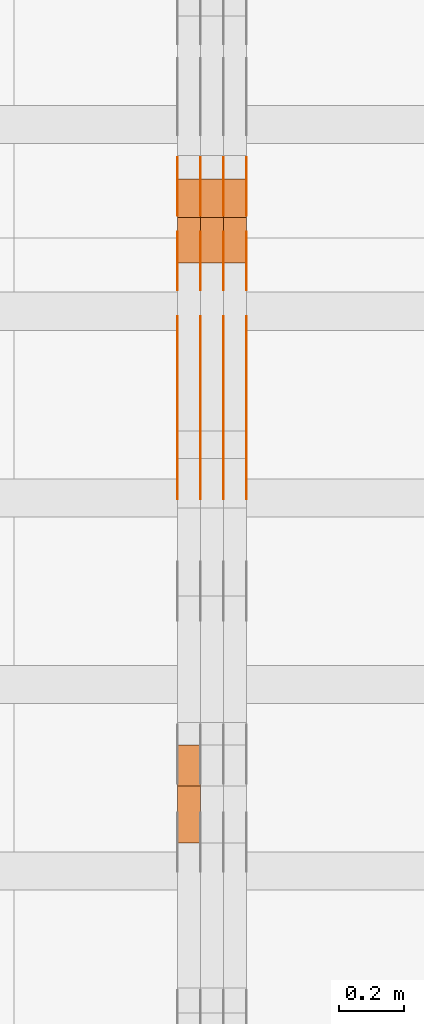
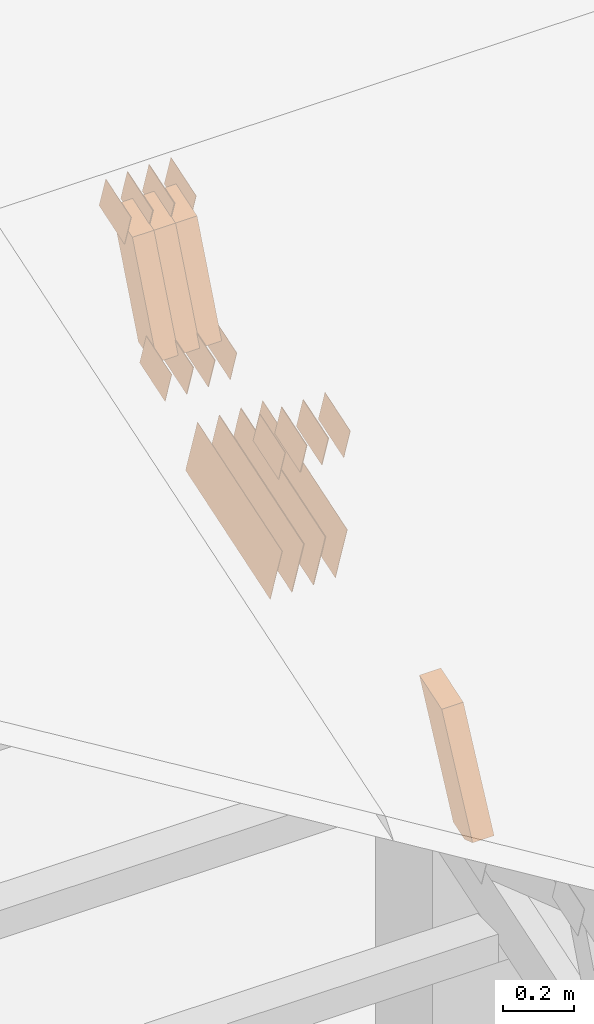
# One storey, part 139 of 385: 28 proxies.
"""IFC2X3 building model written with IfcOpenShell, lengths in millimetres."""

from ifc_helpers import new_model, entity, si_unit, converted_unit, derived_unit, direction, frame, origin, place, context, subcontext, project, spatial, polyline, outline, extrude, source, transform, mapped, material, type_object, type_shapes, element, save


model = new_model("IFC2X3")

# Units and contexts
model_context = context("Model", 3, precision=0.01, world=origin(), true_north=direction((6.12303176911189e-17, 1.0)))
body_context = subcontext(model_context, "Body", "Model", "MODEL_VIEW")
ifc_project = project(units=[si_unit("LENGTHUNIT", "METRE", prefix="MILLI"), si_unit("AREAUNIT", "SQUARE_METRE"), si_unit("VOLUMEUNIT", "CUBIC_METRE"), converted_unit("PLANEANGLEUNIT", "DEGREE", entity("IfcRatioMeasure", 0.0174532925199433), si_unit("PLANEANGLEUNIT", "RADIAN"), dimensions=[0, 0, 0, 0, 0, 0, 0]), si_unit("MASSUNIT", "GRAM", prefix="KILO"), derived_unit("MASSDENSITYUNIT", [(si_unit("MASSUNIT", "GRAM", prefix="KILO"), 1), (si_unit("LENGTHUNIT", "METRE"), -3)]), si_unit("TIMEUNIT", "SECOND"), si_unit("FREQUENCYUNIT", "HERTZ"), si_unit("THERMODYNAMICTEMPERATUREUNIT", "DEGREE_CELSIUS"), derived_unit("THERMALTRANSMITTANCEUNIT", [(si_unit("MASSUNIT", "GRAM", prefix="KILO"), 1), (si_unit("THERMODYNAMICTEMPERATUREUNIT", "KELVIN"), -1), (si_unit("TIMEUNIT", "SECOND"), -3)]), derived_unit("VOLUMETRICFLOWRATEUNIT", [(si_unit("LENGTHUNIT", "METRE"), 3), (si_unit("TIMEUNIT", "SECOND"), -1)]), si_unit("ELECTRICCURRENTUNIT", "AMPERE"), si_unit("ELECTRICVOLTAGEUNIT", "VOLT"), si_unit("POWERUNIT", "WATT"), si_unit("FORCEUNIT", "NEWTON", prefix="KILO"), si_unit("ILLUMINANCEUNIT", "LUX"), si_unit("LUMINOUSFLUXUNIT", "LUMEN"), si_unit("LUMINOUSINTENSITYUNIT", "CANDELA"), derived_unit("USERDEFINED", [(si_unit("MASSUNIT", "GRAM", prefix="KILO"), -1), (si_unit("LENGTHUNIT", "METRE"), -2), (si_unit("TIMEUNIT", "SECOND"), 3), (si_unit("LUMINOUSFLUXUNIT", "LUMEN"), 1)]), derived_unit("LINEARVELOCITYUNIT", [(si_unit("LENGTHUNIT", "METRE"), 1), (si_unit("TIMEUNIT", "SECOND"), -1)]), si_unit("PRESSUREUNIT", "PASCAL"), derived_unit("USERDEFINED", [(si_unit("LENGTHUNIT", "METRE"), -2), (si_unit("MASSUNIT", "GRAM", prefix="KILO"), 1), (si_unit("TIMEUNIT", "SECOND"), -2)])], contexts=[model_context])

# Site, building, storey
site_placement = place(None, origin())
site = spatial("IfcSite", under=ifc_project, at=site_placement, CompositionType="ELEMENT")
building_placement = place(site_placement, origin())
building = spatial("IfcBuilding", under=site, at=building_placement, CompositionType="ELEMENT")
storey_placement = place(building_placement, origin())
storey = spatial("IfcBuildingStorey", under=building, at=storey_placement, Name="Default", CompositionType="ELEMENT", Elevation=0.0)

# Proxies
ifc_material_1 = material(Name="IfcSurfaceStyle #385062")
building_element_proxy_type_1 = type_object("IfcBuildingElementProxyType", PredefinedType="NOTDEFINED", material=ifc_material_1)
shared_shape_1 = source(origin(), body_context, "Body", "SweptSolid", [
    extrude(outline(polyline([(-74.9998565677179, -60.000059685226), (74.9998794200128, -60.000059685226), (74.9998565677179, 60.000059685226), (-74.9998794200128, 60.000059685226), (-74.9998565677179, -60.000059685226)])), frame((75.0001976720505, 60.000059685226, 0.0), z_axis=(0.0, 0.0, 1.0), x_axis=(-1.0, 0.0, 0.0)), (0.0, 0.0, 1.0), 1.3),
])
type_shapes(building_element_proxy_type_1, [shared_shape_1])
proxy_1_placement = place(building_placement, frame((30386.3, 8537.53090236182, 1950.11166041942), z_axis=(-1.0, 0.0, 0.0), x_axis=(0.0, 0.951056516295124, 0.309016994375039)))
element("IfcBuildingElementProxy", 1, at=proxy_1_placement, inside=storey, type_object=building_element_proxy_type_1, material=ifc_material_1, context=body_context, shape_type="MappedRepresentation", body=[
    mapped(shared_shape_1, transform((0.0, 0.0, 0.0), scale=1.0)),
])
ifc_material_2 = material(Name="IfcSurfaceStyle #385005")
building_element_proxy_type_2 = type_object("IfcBuildingElementProxyType", PredefinedType="NOTDEFINED", material=ifc_material_2)
shared_shape_2 = source(origin(), body_context, "Body", "SweptSolid", [
    extrude(outline(polyline([(-74.9998565677179, -60.000059685226), (74.9998794200128, -60.000059685226), (74.9998565677179, 60.000059685226), (-74.9998794200128, 60.000059685226), (-74.9998565677179, -60.000059685226)])), frame((75.0001976720505, 60.000059685226, 0.0), z_axis=(0.0, 0.0, 1.0), x_axis=(-1.0, 0.0, 0.0)), (0.0, 0.0, 1.0), 1.3),
])
type_shapes(building_element_proxy_type_2, [shared_shape_2])
proxy_2_placement = place(building_placement, frame((30315.0, 8537.53090236182, 1950.11166041942), z_axis=(-1.0, 0.0, 0.0), x_axis=(0.0, 0.951056516295124, 0.309016994375039)))
element("IfcBuildingElementProxy", 2, at=proxy_2_placement, inside=storey, type_object=building_element_proxy_type_2, material=ifc_material_2, context=body_context, shape_type="MappedRepresentation", body=[
    mapped(shared_shape_2, transform((0.0, 0.0, 0.0), scale=1.0)),
])
ifc_material_3 = material(Name="IfcSurfaceStyle #384948")
building_element_proxy_type_3 = type_object("IfcBuildingElementProxyType", PredefinedType="NOTDEFINED", material=ifc_material_3)
shared_shape_3 = source(origin(), body_context, "Body", "SweptSolid", [
    extrude(outline(polyline([(-74.9998565677179, -60.000059685226), (74.9998794200128, -60.000059685226), (74.9998565677179, 60.000059685226), (-74.9998794200128, 60.000059685226), (-74.9998565677179, -60.000059685226)])), frame((75.0001976720505, 60.000059685226, 0.0), z_axis=(0.0, 0.0, 1.0), x_axis=(-1.0, 0.0, 0.0)), (0.0, 0.0, 1.0), 1.3),
])
type_shapes(building_element_proxy_type_3, [shared_shape_3])
proxy_3_placement = place(building_placement, frame((30316.3, 8537.53090236182, 1950.11166041942), z_axis=(-1.0, 0.0, 0.0), x_axis=(0.0, 0.951056516295124, 0.309016994375039)))
element("IfcBuildingElementProxy", 3, at=proxy_3_placement, inside=storey, type_object=building_element_proxy_type_3, material=ifc_material_3, context=body_context, shape_type="MappedRepresentation", body=[
    mapped(shared_shape_3, transform((0.0, 0.0, 0.0), scale=1.0)),
])
ifc_material_4 = material(Name="IfcSurfaceStyle #384891")
building_element_proxy_type_4 = type_object("IfcBuildingElementProxyType", PredefinedType="NOTDEFINED", material=ifc_material_4)
shared_shape_4 = source(origin(), body_context, "Body", "SweptSolid", [
    extrude(outline(polyline([(-74.9998565677179, -60.000059685226), (74.9998794200128, -60.000059685226), (74.9998565677179, 60.000059685226), (-74.9998794200128, 60.000059685226), (-74.9998565677179, -60.000059685226)])), frame((75.0001976720505, 60.000059685226, 0.0), z_axis=(0.0, 0.0, 1.0), x_axis=(-1.0, 0.0, 0.0)), (0.0, 0.0, 1.0), 1.29999999999999),
])
type_shapes(building_element_proxy_type_4, [shared_shape_4])
proxy_4_placement = place(building_placement, frame((30245.0, 8537.53090236182, 1950.11166041942), z_axis=(-1.0, 0.0, 0.0), x_axis=(0.0, 0.951056516295124, 0.309016994375039)))
element("IfcBuildingElementProxy", 4, at=proxy_4_placement, inside=storey, type_object=building_element_proxy_type_4, material=ifc_material_4, context=body_context, shape_type="MappedRepresentation", body=[
    mapped(shared_shape_4, transform((0.0, 0.0, 0.0), scale=1.0)),
])
ifc_material_5 = material(Name="IfcSurfaceStyle #384834")
building_element_proxy_type_5 = type_object("IfcBuildingElementProxyType", PredefinedType="NOTDEFINED", material=ifc_material_5)
shared_shape_5 = source(origin(), body_context, "Body", "SweptSolid", [
    extrude(outline(polyline([(-74.9998565677179, -60.000059685226), (74.9998794200128, -60.000059685226), (74.9998565677179, 60.000059685226), (-74.9998794200128, 60.000059685226), (-74.9998565677179, -60.000059685226)])), frame((75.0001976720505, 60.000059685226, 0.0), z_axis=(0.0, 0.0, 1.0), x_axis=(-1.0, 0.0, 0.0)), (0.0, 0.0, 1.0), 1.29999999999999),
])
type_shapes(building_element_proxy_type_5, [shared_shape_5])
proxy_5_placement = place(building_placement, frame((30246.3, 8537.53090236182, 1950.11166041942), z_axis=(-1.0, 0.0, 0.0), x_axis=(0.0, 0.951056516295124, 0.309016994375039)))
element("IfcBuildingElementProxy", 5, at=proxy_5_placement, inside=storey, type_object=building_element_proxy_type_5, material=ifc_material_5, context=body_context, shape_type="MappedRepresentation", body=[
    mapped(shared_shape_5, transform((0.0, 0.0, 0.0), scale=1.0)),
])
ifc_material_6 = material(Name="IfcSurfaceStyle #384777")
building_element_proxy_type_6 = type_object("IfcBuildingElementProxyType", PredefinedType="NOTDEFINED", material=ifc_material_6)
shared_shape_6 = source(origin(), body_context, "Body", "SweptSolid", [
    extrude(outline(polyline([(-74.9998565677179, -60.000059685226), (74.9998794200128, -60.000059685226), (74.9998565677179, 60.000059685226), (-74.9998794200128, 60.000059685226), (-74.9998565677179, -60.000059685226)])), frame((75.0001976720505, 60.000059685226, 0.0), z_axis=(0.0, 0.0, 1.0), x_axis=(-1.0, 0.0, 0.0)), (0.0, 0.0, 1.0), 1.29999999999999),
])
type_shapes(building_element_proxy_type_6, [shared_shape_6])
proxy_6_placement = place(building_placement, frame((30175.0, 8537.53090236182, 1950.11166041942), z_axis=(-1.0, 0.0, 0.0), x_axis=(0.0, 0.951056516295124, 0.309016994375039)))
element("IfcBuildingElementProxy", 6, at=proxy_6_placement, inside=storey, type_object=building_element_proxy_type_6, material=ifc_material_6, context=body_context, shape_type="MappedRepresentation", body=[
    mapped(shared_shape_6, transform((0.0, 0.0, 0.0), scale=1.0)),
])
ifc_material_7 = material(Name="IfcSurfaceStyle #384720")
building_element_proxy_type_7 = type_object("IfcBuildingElementProxyType", PredefinedType="NOTDEFINED", material=ifc_material_7)
shared_shape_7 = source(origin(), body_context, "Body", "SweptSolid", [
    extrude(outline(polyline([(-74.9998754286225, -60.0000016373515), (74.9998605591045, -60.0000016373515), (74.9998754286225, 60.0000016373515), (-74.9998605591045, 60.0000016373515), (-74.9998754286225, -60.0000016373515)])), frame((74.9998754286225, 60.0000016373515, 0.0), z_axis=(0.0, 0.0, 1.0), x_axis=(-1.0, 0.0, 0.0)), (0.0, 0.0, 1.0), 1.3),
])
type_shapes(building_element_proxy_type_7, [shared_shape_7])
proxy_7_placement = place(building_placement, frame((30386.3, 8765.47458614632, 2350.86432930304), z_axis=(-1.0, 0.0, 0.0), x_axis=(0.0, 0.951056516295154, 0.309016994374948)))
element("IfcBuildingElementProxy", 7, at=proxy_7_placement, inside=storey, type_object=building_element_proxy_type_7, material=ifc_material_7, context=body_context, shape_type="MappedRepresentation", body=[
    mapped(shared_shape_7, transform((0.0, 0.0, 0.0), scale=1.0)),
])
ifc_material_8 = material(Name="IfcSurfaceStyle #384663")
building_element_proxy_type_8 = type_object("IfcBuildingElementProxyType", PredefinedType="NOTDEFINED", material=ifc_material_8)
shared_shape_8 = source(origin(), body_context, "Body", "SweptSolid", [
    extrude(outline(polyline([(-74.9998754286225, -60.0000016373515), (74.9998605591045, -60.0000016373515), (74.9998754286225, 60.0000016373515), (-74.9998605591045, 60.0000016373515), (-74.9998754286225, -60.0000016373515)])), frame((74.9998754286225, 60.0000016373515, 0.0), z_axis=(0.0, 0.0, 1.0), x_axis=(-1.0, 0.0, 0.0)), (0.0, 0.0, 1.0), 1.3),
])
type_shapes(building_element_proxy_type_8, [shared_shape_8])
proxy_8_placement = place(building_placement, frame((30315.0, 8765.47458614632, 2350.86432930304), z_axis=(-1.0, 0.0, 0.0), x_axis=(0.0, 0.951056516295154, 0.309016994374948)))
element("IfcBuildingElementProxy", 8, at=proxy_8_placement, inside=storey, type_object=building_element_proxy_type_8, material=ifc_material_8, context=body_context, shape_type="MappedRepresentation", body=[
    mapped(shared_shape_8, transform((0.0, 0.0, 0.0), scale=1.0)),
])
ifc_material_9 = material(Name="IfcSurfaceStyle #384606")
building_element_proxy_type_9 = type_object("IfcBuildingElementProxyType", PredefinedType="NOTDEFINED", material=ifc_material_9)
shared_shape_9 = source(origin(), body_context, "Body", "SweptSolid", [
    extrude(outline(polyline([(-74.9998754286225, -60.0000016373515), (74.9998605591045, -60.0000016373515), (74.9998754286225, 60.0000016373515), (-74.9998605591045, 60.0000016373515), (-74.9998754286225, -60.0000016373515)])), frame((74.9998754286225, 60.0000016373515, 0.0), z_axis=(0.0, 0.0, 1.0), x_axis=(-1.0, 0.0, 0.0)), (0.0, 0.0, 1.0), 1.3),
])
type_shapes(building_element_proxy_type_9, [shared_shape_9])
proxy_9_placement = place(building_placement, frame((30316.3, 8765.47458614632, 2350.86432930304), z_axis=(-1.0, 0.0, 0.0), x_axis=(0.0, 0.951056516295154, 0.309016994374948)))
element("IfcBuildingElementProxy", 9, at=proxy_9_placement, inside=storey, type_object=building_element_proxy_type_9, material=ifc_material_9, context=body_context, shape_type="MappedRepresentation", body=[
    mapped(shared_shape_9, transform((0.0, 0.0, 0.0), scale=1.0)),
])
ifc_material_10 = material(Name="IfcSurfaceStyle #384549")
building_element_proxy_type_10 = type_object("IfcBuildingElementProxyType", PredefinedType="NOTDEFINED", material=ifc_material_10)
shared_shape_10 = source(origin(), body_context, "Body", "SweptSolid", [
    extrude(outline(polyline([(-74.9998754286225, -60.0000016373515), (74.9998605591045, -60.0000016373515), (74.9998754286225, 60.0000016373515), (-74.9998605591045, 60.0000016373515), (-74.9998754286225, -60.0000016373515)])), frame((74.9998754286225, 60.0000016373515, 0.0), z_axis=(0.0, 0.0, 1.0), x_axis=(-1.0, 0.0, 0.0)), (0.0, 0.0, 1.0), 1.29999999999999),
])
type_shapes(building_element_proxy_type_10, [shared_shape_10])
proxy_10_placement = place(building_placement, frame((30245.0, 8765.47458614632, 2350.86432930304), z_axis=(-1.0, 0.0, 0.0), x_axis=(0.0, 0.951056516295154, 0.309016994374948)))
element("IfcBuildingElementProxy", 10, at=proxy_10_placement, inside=storey, type_object=building_element_proxy_type_10, material=ifc_material_10, context=body_context, shape_type="MappedRepresentation", body=[
    mapped(shared_shape_10, transform((0.0, 0.0, 0.0), scale=1.0)),
])
ifc_material_11 = material(Name="IfcSurfaceStyle #384492")
building_element_proxy_type_11 = type_object("IfcBuildingElementProxyType", PredefinedType="NOTDEFINED", material=ifc_material_11)
shared_shape_11 = source(origin(), body_context, "Body", "SweptSolid", [
    extrude(outline(polyline([(-74.9998754286225, -60.0000016373515), (74.9998605591045, -60.0000016373515), (74.9998754286225, 60.0000016373515), (-74.9998605591045, 60.0000016373515), (-74.9998754286225, -60.0000016373515)])), frame((74.9998754286225, 60.0000016373515, 0.0), z_axis=(0.0, 0.0, 1.0), x_axis=(-1.0, 0.0, 0.0)), (0.0, 0.0, 1.0), 1.29999999999999),
])
type_shapes(building_element_proxy_type_11, [shared_shape_11])
proxy_11_placement = place(building_placement, frame((30246.3, 8765.47458614632, 2350.86432930304), z_axis=(-1.0, 0.0, 0.0), x_axis=(0.0, 0.951056516295154, 0.309016994374948)))
element("IfcBuildingElementProxy", 11, at=proxy_11_placement, inside=storey, type_object=building_element_proxy_type_11, material=ifc_material_11, context=body_context, shape_type="MappedRepresentation", body=[
    mapped(shared_shape_11, transform((0.0, 0.0, 0.0), scale=1.0)),
])
ifc_material_12 = material(Name="IfcSurfaceStyle #384435")
building_element_proxy_type_12 = type_object("IfcBuildingElementProxyType", PredefinedType="NOTDEFINED", material=ifc_material_12)
shared_shape_12 = source(origin(), body_context, "Body", "SweptSolid", [
    extrude(outline(polyline([(-74.9998754286225, -60.0000016373515), (74.9998605591045, -60.0000016373515), (74.9998754286225, 60.0000016373515), (-74.9998605591045, 60.0000016373515), (-74.9998754286225, -60.0000016373515)])), frame((74.9998754286225, 60.0000016373515, 0.0), z_axis=(0.0, 0.0, 1.0), x_axis=(-1.0, 0.0, 0.0)), (0.0, 0.0, 1.0), 1.29999999999999),
])
type_shapes(building_element_proxy_type_12, [shared_shape_12])
proxy_12_placement = place(building_placement, frame((30175.0, 8765.47458614632, 2350.86432930304), z_axis=(-1.0, 0.0, 0.0), x_axis=(0.0, 0.951056516295154, 0.309016994374948)))
element("IfcBuildingElementProxy", 12, at=proxy_12_placement, inside=storey, type_object=building_element_proxy_type_12, material=ifc_material_12, context=body_context, shape_type="MappedRepresentation", body=[
    mapped(shared_shape_12, transform((0.0, 0.0, 0.0), scale=1.0)),
])
ifc_material_13 = material(Name="IfcSurfaceStyle #384036")
building_element_proxy_type_13 = type_object("IfcBuildingElementProxyType", PredefinedType="NOTDEFINED", material=ifc_material_13)
shared_shape_13 = source(origin(), body_context, "Body", "SweptSolid", [
    extrude(outline(polyline([(-249.999749056184, -108.000229288163), (249.999396050782, -108.000229288163), (249.999749056184, 108.000229288163), (-249.999396050782, 108.000229288163), (-249.999749056184, -108.000229288163)])), frame((249.999841104007, 108.000229288163, 0.0), z_axis=(0.0, 0.0, 1.0), x_axis=(-1.0, 0.0, 0.0)), (0.0, 0.0, 1.0), 1.29999999999998),
])
type_shapes(building_element_proxy_type_13, [shared_shape_13])
proxy_13_placement = place(building_placement, frame((30386.3, 7917.13457673635, 1720.66532252899), z_axis=(-1.0, 0.0, 0.0), x_axis=(0.0, 0.951056516295124, 0.309016994375039)))
element("IfcBuildingElementProxy", 13, at=proxy_13_placement, inside=storey, type_object=building_element_proxy_type_13, material=ifc_material_13, context=body_context, shape_type="MappedRepresentation", body=[
    mapped(shared_shape_13, transform((0.0, 0.0, 0.0), scale=1.0)),
])
ifc_material_14 = material(Name="IfcSurfaceStyle #383979")
building_element_proxy_type_14 = type_object("IfcBuildingElementProxyType", PredefinedType="NOTDEFINED", material=ifc_material_14)
shared_shape_14 = source(origin(), body_context, "Body", "SweptSolid", [
    extrude(outline(polyline([(-249.999749056184, -108.000229288163), (249.999396050782, -108.000229288163), (249.999749056184, 108.000229288163), (-249.999396050782, 108.000229288163), (-249.999749056184, -108.000229288163)])), frame((249.999841104007, 108.000229288163, 0.0), z_axis=(0.0, 0.0, 1.0), x_axis=(-1.0, 0.0, 0.0)), (0.0, 0.0, 1.0), 1.29999999999998),
])
type_shapes(building_element_proxy_type_14, [shared_shape_14])
proxy_14_placement = place(building_placement, frame((30315.0, 7917.13457673635, 1720.66532252899), z_axis=(-1.0, 0.0, 0.0), x_axis=(0.0, 0.951056516295124, 0.309016994375039)))
element("IfcBuildingElementProxy", 14, at=proxy_14_placement, inside=storey, type_object=building_element_proxy_type_14, material=ifc_material_14, context=body_context, shape_type="MappedRepresentation", body=[
    mapped(shared_shape_14, transform((0.0, 0.0, 0.0), scale=1.0)),
])
ifc_material_15 = material(Name="IfcSurfaceStyle #383922")
building_element_proxy_type_15 = type_object("IfcBuildingElementProxyType", PredefinedType="NOTDEFINED", material=ifc_material_15)
shared_shape_15 = source(origin(), body_context, "Body", "SweptSolid", [
    extrude(outline(polyline([(-249.999749056184, -108.000229288163), (249.999396050782, -108.000229288163), (249.999749056184, 108.000229288163), (-249.999396050782, 108.000229288163), (-249.999749056184, -108.000229288163)])), frame((249.999841104007, 108.000229288163, 0.0), z_axis=(0.0, 0.0, 1.0), x_axis=(-1.0, 0.0, 0.0)), (0.0, 0.0, 1.0), 1.29999999999998),
])
type_shapes(building_element_proxy_type_15, [shared_shape_15])
proxy_15_placement = place(building_placement, frame((30316.3, 7917.13457673635, 1720.66532252899), z_axis=(-1.0, 0.0, 0.0), x_axis=(0.0, 0.951056516295124, 0.309016994375039)))
element("IfcBuildingElementProxy", 15, at=proxy_15_placement, inside=storey, type_object=building_element_proxy_type_15, material=ifc_material_15, context=body_context, shape_type="MappedRepresentation", body=[
    mapped(shared_shape_15, transform((0.0, 0.0, 0.0), scale=1.0)),
])
ifc_material_16 = material(Name="IfcSurfaceStyle #383865")
building_element_proxy_type_16 = type_object("IfcBuildingElementProxyType", PredefinedType="NOTDEFINED", material=ifc_material_16)
shared_shape_16 = source(origin(), body_context, "Body", "SweptSolid", [
    extrude(outline(polyline([(-249.999749056184, -108.000229288163), (249.999396050782, -108.000229288163), (249.999749056184, 108.000229288163), (-249.999396050782, 108.000229288163), (-249.999749056184, -108.000229288163)])), frame((249.999841104007, 108.000229288163, 0.0), z_axis=(0.0, 0.0, 1.0), x_axis=(-1.0, 0.0, 0.0)), (0.0, 0.0, 1.0), 1.29999999999997),
])
type_shapes(building_element_proxy_type_16, [shared_shape_16])
proxy_16_placement = place(building_placement, frame((30245.0, 7917.13457673635, 1720.66532252899), z_axis=(-1.0, 0.0, 0.0), x_axis=(0.0, 0.951056516295124, 0.309016994375039)))
element("IfcBuildingElementProxy", 16, at=proxy_16_placement, inside=storey, type_object=building_element_proxy_type_16, material=ifc_material_16, context=body_context, shape_type="MappedRepresentation", body=[
    mapped(shared_shape_16, transform((0.0, 0.0, 0.0), scale=1.0)),
])
ifc_material_17 = material(Name="IfcSurfaceStyle #383808")
building_element_proxy_type_17 = type_object("IfcBuildingElementProxyType", PredefinedType="NOTDEFINED", material=ifc_material_17)
shared_shape_17 = source(origin(), body_context, "Body", "SweptSolid", [
    extrude(outline(polyline([(-249.999749056184, -108.000229288163), (249.999396050782, -108.000229288163), (249.999749056184, 108.000229288163), (-249.999396050782, 108.000229288163), (-249.999749056184, -108.000229288163)])), frame((249.999841104007, 108.000229288163, 0.0), z_axis=(0.0, 0.0, 1.0), x_axis=(-1.0, 0.0, 0.0)), (0.0, 0.0, 1.0), 1.29999999999997),
])
type_shapes(building_element_proxy_type_17, [shared_shape_17])
proxy_17_placement = place(building_placement, frame((30246.3, 7917.13457673635, 1720.66532252899), z_axis=(-1.0, 0.0, 0.0), x_axis=(0.0, 0.951056516295124, 0.309016994375039)))
element("IfcBuildingElementProxy", 17, at=proxy_17_placement, inside=storey, type_object=building_element_proxy_type_17, material=ifc_material_17, context=body_context, shape_type="MappedRepresentation", body=[
    mapped(shared_shape_17, transform((0.0, 0.0, 0.0), scale=1.0)),
])
ifc_material_18 = material(Name="IfcSurfaceStyle #383751")
building_element_proxy_type_18 = type_object("IfcBuildingElementProxyType", PredefinedType="NOTDEFINED", material=ifc_material_18)
shared_shape_18 = source(origin(), body_context, "Body", "SweptSolid", [
    extrude(outline(polyline([(-249.999749056184, -108.000229288163), (249.999396050782, -108.000229288163), (249.999749056184, 108.000229288163), (-249.999396050782, 108.000229288163), (-249.999749056184, -108.000229288163)])), frame((249.999841104007, 108.000229288163, 0.0), z_axis=(0.0, 0.0, 1.0), x_axis=(-1.0, 0.0, 0.0)), (0.0, 0.0, 1.0), 1.29999999999997),
])
type_shapes(building_element_proxy_type_18, [shared_shape_18])
proxy_18_placement = place(building_placement, frame((30175.0, 7917.13457673635, 1720.66532252899), z_axis=(-1.0, 0.0, 0.0), x_axis=(0.0, 0.951056516295124, 0.309016994375039)))
element("IfcBuildingElementProxy", 18, at=proxy_18_placement, inside=storey, type_object=building_element_proxy_type_18, material=ifc_material_18, context=body_context, shape_type="MappedRepresentation", body=[
    mapped(shared_shape_18, transform((0.0, 0.0, 0.0), scale=1.0)),
])
ifc_material_19 = material(Name="IfcSurfaceStyle #370356")
building_element_proxy_type_19 = type_object("IfcBuildingElementProxyType", PredefinedType="NOTDEFINED", material=ifc_material_19)
shared_shape_19 = source(origin(), body_context, "Body", "SweptSolid", [
    extrude(outline(polyline([(-74.9998754286253, -60.0000016373506), (74.9998605591091, -60.0000016373506), (74.9998754286234, 60.0000016373506), (-74.9998605591072, 60.0000016373506), (-74.9998754286253, -60.0000016373506)])), frame((75.0007355357002, 60.0002637031812, 0.0), z_axis=(0.0, 0.0, 1.0), x_axis=(-1.0, 0.0, 0.0)), (0.0, 0.0, 1.0), 1.3),
])
type_shapes(building_element_proxy_type_19, [shared_shape_19])
proxy_19_placement = place(building_placement, frame((30386.3, 7899.79204652808, 2069.58672486412), z_axis=(-1.0, 0.0, 0.0), x_axis=(0.0, 0.951056516295154, 0.309016994374948)))
element("IfcBuildingElementProxy", 19, at=proxy_19_placement, inside=storey, type_object=building_element_proxy_type_19, material=ifc_material_19, context=body_context, shape_type="MappedRepresentation", body=[
    mapped(shared_shape_19, transform((0.0, 0.0, 0.0), scale=1.0)),
])
ifc_material_20 = material(Name="IfcSurfaceStyle #370299")
building_element_proxy_type_20 = type_object("IfcBuildingElementProxyType", PredefinedType="NOTDEFINED", material=ifc_material_20)
shared_shape_20 = source(origin(), body_context, "Body", "SweptSolid", [
    extrude(outline(polyline([(-74.9998754286253, -60.0000016373506), (74.9998605591091, -60.0000016373506), (74.9998754286234, 60.0000016373506), (-74.9998605591072, 60.0000016373506), (-74.9998754286253, -60.0000016373506)])), frame((75.0007355357002, 60.0002637031812, 0.0), z_axis=(0.0, 0.0, 1.0), x_axis=(-1.0, 0.0, 0.0)), (0.0, 0.0, 1.0), 1.3),
])
type_shapes(building_element_proxy_type_20, [shared_shape_20])
proxy_20_placement = place(building_placement, frame((30315.0, 7899.79204652808, 2069.58672486412), z_axis=(-1.0, 0.0, 0.0), x_axis=(0.0, 0.951056516295154, 0.309016994374948)))
element("IfcBuildingElementProxy", 20, at=proxy_20_placement, inside=storey, type_object=building_element_proxy_type_20, material=ifc_material_20, context=body_context, shape_type="MappedRepresentation", body=[
    mapped(shared_shape_20, transform((0.0, 0.0, 0.0), scale=1.0)),
])
ifc_material_21 = material(Name="IfcSurfaceStyle #370242")
building_element_proxy_type_21 = type_object("IfcBuildingElementProxyType", PredefinedType="NOTDEFINED", material=ifc_material_21)
shared_shape_21 = source(origin(), body_context, "Body", "SweptSolid", [
    extrude(outline(polyline([(-74.9998754286253, -60.0000016373506), (74.9998605591091, -60.0000016373506), (74.9998754286234, 60.0000016373506), (-74.9998605591072, 60.0000016373506), (-74.9998754286253, -60.0000016373506)])), frame((75.0007355357002, 60.0002637031812, 0.0), z_axis=(0.0, 0.0, 1.0), x_axis=(-1.0, 0.0, 0.0)), (0.0, 0.0, 1.0), 1.3),
])
type_shapes(building_element_proxy_type_21, [shared_shape_21])
proxy_21_placement = place(building_placement, frame((30316.3, 7899.79204652808, 2069.58672486412), z_axis=(-1.0, 0.0, 0.0), x_axis=(0.0, 0.951056516295154, 0.309016994374948)))
element("IfcBuildingElementProxy", 21, at=proxy_21_placement, inside=storey, type_object=building_element_proxy_type_21, material=ifc_material_21, context=body_context, shape_type="MappedRepresentation", body=[
    mapped(shared_shape_21, transform((0.0, 0.0, 0.0), scale=1.0)),
])
ifc_material_22 = material(Name="IfcSurfaceStyle #370185")
building_element_proxy_type_22 = type_object("IfcBuildingElementProxyType", PredefinedType="NOTDEFINED", material=ifc_material_22)
shared_shape_22 = source(origin(), body_context, "Body", "SweptSolid", [
    extrude(outline(polyline([(-74.9998754286253, -60.0000016373506), (74.9998605591091, -60.0000016373506), (74.9998754286234, 60.0000016373506), (-74.9998605591072, 60.0000016373506), (-74.9998754286253, -60.0000016373506)])), frame((75.0007355357002, 60.0002637031812, 0.0), z_axis=(0.0, 0.0, 1.0), x_axis=(-1.0, 0.0, 0.0)), (0.0, 0.0, 1.0), 1.29999999999999),
])
type_shapes(building_element_proxy_type_22, [shared_shape_22])
proxy_22_placement = place(building_placement, frame((30245.0, 7899.79204652808, 2069.58672486412), z_axis=(-1.0, 0.0, 0.0), x_axis=(0.0, 0.951056516295154, 0.309016994374948)))
element("IfcBuildingElementProxy", 22, at=proxy_22_placement, inside=storey, type_object=building_element_proxy_type_22, material=ifc_material_22, context=body_context, shape_type="MappedRepresentation", body=[
    mapped(shared_shape_22, transform((0.0, 0.0, 0.0), scale=1.0)),
])
ifc_material_23 = material(Name="IfcSurfaceStyle #370128")
building_element_proxy_type_23 = type_object("IfcBuildingElementProxyType", PredefinedType="NOTDEFINED", material=ifc_material_23)
shared_shape_23 = source(origin(), body_context, "Body", "SweptSolid", [
    extrude(outline(polyline([(-74.9998754286253, -60.0000016373506), (74.9998605591091, -60.0000016373506), (74.9998754286234, 60.0000016373506), (-74.9998605591072, 60.0000016373506), (-74.9998754286253, -60.0000016373506)])), frame((75.0007355357002, 60.0002637031812, 0.0), z_axis=(0.0, 0.0, 1.0), x_axis=(-1.0, 0.0, 0.0)), (0.0, 0.0, 1.0), 1.29999999999999),
])
type_shapes(building_element_proxy_type_23, [shared_shape_23])
proxy_23_placement = place(building_placement, frame((30246.3, 7899.79204652808, 2069.58672486412), z_axis=(-1.0, 0.0, 0.0), x_axis=(0.0, 0.951056516295154, 0.309016994374948)))
element("IfcBuildingElementProxy", 23, at=proxy_23_placement, inside=storey, type_object=building_element_proxy_type_23, material=ifc_material_23, context=body_context, shape_type="MappedRepresentation", body=[
    mapped(shared_shape_23, transform((0.0, 0.0, 0.0), scale=1.0)),
])
ifc_material_24 = material(Name="IfcSurfaceStyle #370071")
building_element_proxy_type_24 = type_object("IfcBuildingElementProxyType", PredefinedType="NOTDEFINED", material=ifc_material_24)
shared_shape_24 = source(origin(), body_context, "Body", "SweptSolid", [
    extrude(outline(polyline([(-74.9998754286253, -60.0000016373506), (74.9998605591091, -60.0000016373506), (74.9998754286234, 60.0000016373506), (-74.9998605591072, 60.0000016373506), (-74.9998754286253, -60.0000016373506)])), frame((75.0007355357002, 60.0002637031812, 0.0), z_axis=(0.0, 0.0, 1.0), x_axis=(-1.0, 0.0, 0.0)), (0.0, 0.0, 1.0), 1.29999999999999),
])
type_shapes(building_element_proxy_type_24, [shared_shape_24])
proxy_24_placement = place(building_placement, frame((30175.0, 7899.79204652808, 2069.58672486412), z_axis=(-1.0, 0.0, 0.0), x_axis=(0.0, 0.951056516295154, 0.309016994374948)))
element("IfcBuildingElementProxy", 24, at=proxy_24_placement, inside=storey, type_object=building_element_proxy_type_24, material=ifc_material_24, context=body_context, shape_type="MappedRepresentation", body=[
    mapped(shared_shape_24, transform((0.0, 0.0, 0.0), scale=1.0)),
])
ifc_material_25 = material(Name="IfcSurfaceStyle #357972")
building_element_proxy_type_25 = type_object("IfcBuildingElementProxyType", Name="T1-W45 357970", PredefinedType="NOTDEFINED", material=ifc_material_25)
shared_shape_25 = source(origin(), body_context, "Body", "SweptSolid", [
    extrude(outline(polyline([(-275.953018340717, -47.500197738425), (128.971267956636, -47.5001977384251), (168.669977842085, -0.000132525443043008), (174.867371111815, 47.5002640011466), (-196.55559856982, 47.5002640011466), (-275.953018340717, -47.500197738425)])), frame((174.867371111815, 47.5002640011466, 0.0), z_axis=(0.0, 0.0, 1.0), x_axis=(-1.0, 0.0, 0.0)), (0.0, 0.0, 1.0), 70.0),
])
type_shapes(building_element_proxy_type_25, [shared_shape_25])
proxy_25_placement = place(building_placement, frame((30385.0, 8621.494140625, 1941.33422851563), z_axis=(-1.0, 0.0, 0.0), x_axis=(0.0, 0.372787901688292, 0.927916580493549)))
element("IfcBuildingElementProxy", 25, at=proxy_25_placement, inside=storey, type_object=building_element_proxy_type_25, material=ifc_material_25, Name="T1-W45", context=body_context, shape_type="MappedRepresentation", body=[
    mapped(shared_shape_25, transform((0.0, 0.0, 0.0), scale=1.0)),
])
ifc_material_26 = material(Name="IfcSurfaceStyle #357906")
building_element_proxy_type_26 = type_object("IfcBuildingElementProxyType", Name="T1-W45 357904", PredefinedType="NOTDEFINED", material=ifc_material_26)
shared_shape_26 = source(origin(), body_context, "Body", "SweptSolid", [
    extrude(outline(polyline([(-275.953018340717, -47.500197738425), (128.971267956636, -47.5001977384251), (168.669977842085, -0.000132525443043008), (174.867371111815, 47.5002640011466), (-196.55559856982, 47.5002640011466), (-275.953018340717, -47.500197738425)])), frame((174.867371111815, 47.5002640011466, 0.0), z_axis=(0.0, 0.0, 1.0), x_axis=(-1.0, 0.0, 0.0)), (0.0, 0.0, 1.0), 70.0),
])
type_shapes(building_element_proxy_type_26, [shared_shape_26])
proxy_26_placement = place(building_placement, frame((30315.0, 8621.494140625, 1941.33422851563), z_axis=(-1.0, 0.0, 0.0), x_axis=(0.0, 0.372787901688292, 0.927916580493549)))
element("IfcBuildingElementProxy", 26, at=proxy_26_placement, inside=storey, type_object=building_element_proxy_type_26, material=ifc_material_26, Name="T1-W45", context=body_context, shape_type="MappedRepresentation", body=[
    mapped(shared_shape_26, transform((0.0, 0.0, 0.0), scale=1.0)),
])
ifc_material_27 = material(Name="IfcSurfaceStyle #357840")
building_element_proxy_type_27 = type_object("IfcBuildingElementProxyType", Name="T1-W45 357838", PredefinedType="NOTDEFINED", material=ifc_material_27)
shared_shape_27 = source(origin(), body_context, "Body", "SweptSolid", [
    extrude(outline(polyline([(-275.953018340717, -47.500197738425), (128.971267956636, -47.5001977384251), (168.669977842085, -0.000132525443043008), (174.867371111815, 47.5002640011466), (-196.55559856982, 47.5002640011466), (-275.953018340717, -47.500197738425)])), frame((174.867371111815, 47.5002640011466, 0.0), z_axis=(0.0, 0.0, 1.0), x_axis=(-1.0, 0.0, 0.0)), (0.0, 0.0, 1.0), 70.0),
])
type_shapes(building_element_proxy_type_27, [shared_shape_27])
proxy_27_placement = place(building_placement, frame((30245.0, 8621.494140625, 1941.33422851563), z_axis=(-1.0, 0.0, 0.0), x_axis=(0.0, 0.372787901688292, 0.927916580493549)))
element("IfcBuildingElementProxy", 27, at=proxy_27_placement, inside=storey, type_object=building_element_proxy_type_27, material=ifc_material_27, Name="T1-W45", context=body_context, shape_type="MappedRepresentation", body=[
    mapped(shared_shape_27, transform((0.0, 0.0, 0.0), scale=1.0)),
])
ifc_material_28 = material(Name="IfcSurfaceStyle #356256")
building_element_proxy_type_28 = type_object("IfcBuildingElementProxyType", Name="T1-W38 356254", PredefinedType="NOTDEFINED", material=ifc_material_28)
shared_shape_28 = source(origin(), body_context, "Body", "SweptSolid", [
    extrude(outline(polyline([(-298.027186733919, -47.5000251939178), (135.138415004037, -47.5000251939178), (181.282052802132, 0.000918984287993996), (187.347601017465, 47.4995657017738), (-205.740882089715, 47.4995657017739), (-298.027186733919, -47.5000251939178)])), frame((187.347846776827, 47.5001085012031, 0.0), z_axis=(0.0, 0.0, 1.0), x_axis=(-1.0, 0.0, 0.0)), (0.0, 0.0, 1.0), 70.0),
])
type_shapes(building_element_proxy_type_28, [shared_shape_28])
proxy_28_placement = place(building_placement, frame((30245.0, 6848.47987320449, 1368.44362234215), z_axis=(-1.0, 0.0, 0.0), x_axis=(0.0, 0.441034274474743, 0.897490261082836)))
element("IfcBuildingElementProxy", 28, at=proxy_28_placement, inside=storey, type_object=building_element_proxy_type_28, material=ifc_material_28, Name="T1-W38", context=body_context, shape_type="MappedRepresentation", body=[
    mapped(shared_shape_28, transform((0.0, 0.0, 0.0), scale=1.0)),
])

save(model, "model.ifc")
